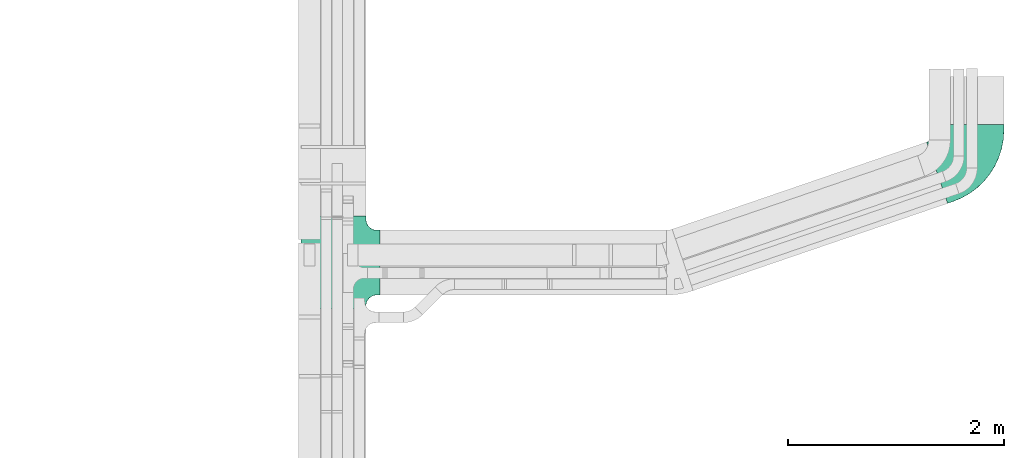
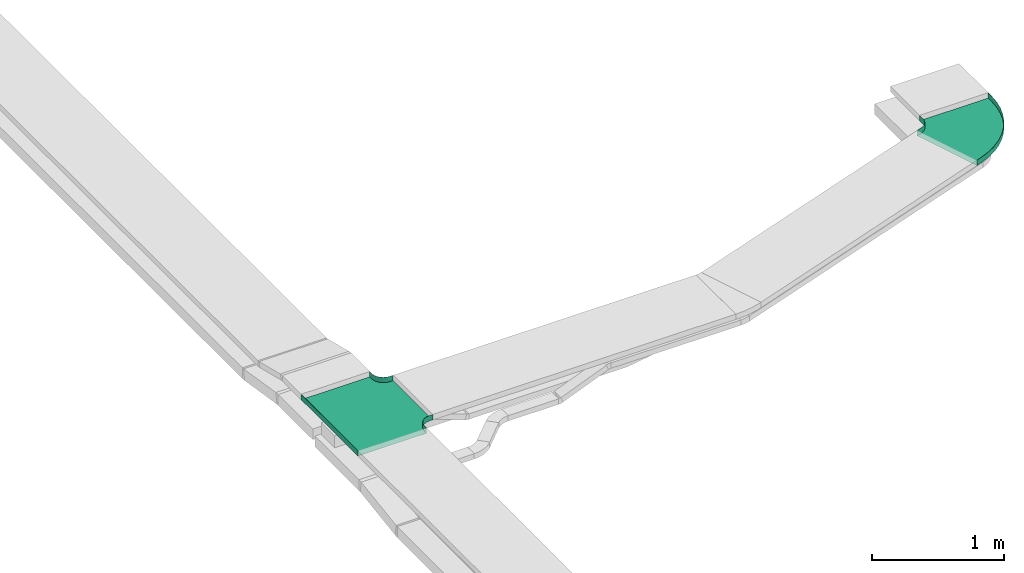
# One storey, part 25 of 28: 2 flow fittings.
"""IFC2X3 building model written with IfcOpenShell, lengths in millimetres."""

import ifcopenshell
import ifcopenshell.guid

model = None  # the IFC model being written
_history = None  # IfcOwnerHistory: only IFC2X3 demands one
_inside = {}  # id of a spatial element -> (the spatial element, [elements in it])
_under = {}  # id of a project, library or spatial element -> (it, [spatial elements below it])
_declared = {}  # id of a project -> (the project, [libraries it declares])
_typed = {}  # id of a type object -> (the type object, [elements of that type])
_made_of = {}  # id of a material, layer set ... -> (it, [elements and type objects made of it])


def new_model(schema):
    """Start an empty IFC model of exactly this schema.

    Asked for "IFC4X3", IfcOpenShell would pick the latest addendum, in which some entities
    have other attributes; the version numbers below select the first issue.
    IFC2X3 requires an IfcOwnerHistory on every rooted entity: one is made here for all.
    """
    global model, _history
    if schema == "IFC4X3":
        model = ifcopenshell.file(schema_version=(4, 3, 0, 0))
    else:
        model = ifcopenshell.file(schema=schema)
    _inside.clear()
    _under.clear()
    _declared.clear()
    _typed.clear()
    _made_of.clear()
    _history = None
    if model.schema == "IFC2X3":
        org = make("IfcOrganization", Name="unknown")
        user = make(
            "IfcPersonAndOrganization",
            ThePerson=make("IfcPerson", FamilyName="unknown"),
            TheOrganization=org,
        )
        app = make(
            "IfcApplication",
            ApplicationDeveloper=org,
            Version="unknown",
            ApplicationFullName="unknown",
            ApplicationIdentifier="unknown",
        )
        _history = make(
            "IfcOwnerHistory",
            OwningUser=user,
            OwningApplication=app,
            ChangeAction="ADDED",
            CreationDate=0,
        )
    return model


def make(cls, **values):
    """One entity of the class cls with the attributes given. An attribute that is None is left unset."""
    return model.create_entity(
        cls, **{name: value for name, value in values.items() if value is not None}
    )


def entity(cls, *values):
    """Any entity or typed value of the class cls, its attributes in the order of the schema. None: left unset."""
    e = model.create_entity(cls)
    for i, value in enumerate(values):
        if value is not None:
            e[i] = value
    return e


def rooted(cls, **values):
    """An entity with a GlobalId (a new one), such as an element, a storey or a relation."""
    return make(cls, GlobalId=ifcopenshell.guid.new(), OwnerHistory=_history, **values)


def si_unit(unit_type, name, prefix=None):
    """IfcSIUnit, for example si_unit("LENGTHUNIT", "METRE", prefix="MILLI")."""
    return make("IfcSIUnit", UnitType=unit_type, Prefix=prefix, Name=name)


def converted_unit(unit_type, name, factor, base, dimensions=None, offset=None):
    """IfcConversionBasedUnit, such as the inch: factor (a typed value) times the base unit."""
    return make(
        "IfcConversionBasedUnit"
        if offset is None
        else "IfcConversionBasedUnitWithOffset",
        ConversionOffset=offset,
        Dimensions=None
        if dimensions is None
        else entity("IfcDimensionalExponents", *dimensions),
        UnitType=unit_type,
        Name=name,
        ConversionFactor=make(
            "IfcMeasureWithUnit", ValueComponent=factor, UnitComponent=base
        ),
    )


def derived_unit(unit_type, elements):
    """IfcDerivedUnit: a product of units, each with its exponent."""
    return make(
        "IfcDerivedUnit",
        Elements=[
            make("IfcDerivedUnitElement", Unit=unit, Exponent=power)
            for unit, power in elements
        ],
        UnitType=unit_type,
    )


def assignment(units):
    """IfcUnitAssignment: the units of a project."""
    return None if units is None else make("IfcUnitAssignment", Units=units)


def point(xyz):
    """IfcCartesianPoint."""
    return None if xyz is None else make("IfcCartesianPoint", Coordinates=xyz)


def direction(xyz):
    """IfcDirection."""
    return None if xyz is None else make("IfcDirection", DirectionRatios=xyz)


def frame(location, z_axis=None, x_axis=None):
    """IfcAxis2Placement3D, a coordinate frame: its origin and axes. An axis left out is left unset."""
    return make(
        "IfcAxis2Placement3D",
        Location=point(location),
        Axis=direction(z_axis),
        RefDirection=direction(x_axis),
    )


def origin():
    """The frame at (0, 0, 0) with its axes left unset."""
    return frame((0.0, 0.0, 0.0))


def place(relative_to, where):
    """IfcLocalPlacement: puts the frame where relative to a parent placement (None: the world)."""
    return make(
        "IfcLocalPlacement", PlacementRelTo=relative_to, RelativePlacement=where
    )


def context(
    kind, dimensions, precision=None, world=None, true_north=None, identifier=None
):
    """IfcGeometricRepresentationContext, for example the 3D "Model" context."""
    return make(
        "IfcGeometricRepresentationContext",
        ContextIdentifier=identifier,
        ContextType=kind,
        CoordinateSpaceDimension=dimensions,
        Precision=precision,
        WorldCoordinateSystem=world,
        TrueNorth=true_north,
    )


def subcontext(parent, identifier, kind, view, scale=None):
    """IfcGeometricRepresentationSubContext, for example "Body" below "Model"."""
    return make(
        "IfcGeometricRepresentationSubContext",
        ContextIdentifier=identifier,
        ContextType=kind,
        ParentContext=parent,
        TargetScale=scale,
        TargetView=view,
    )


def project(units=None, contexts=None):
    """IfcProject with its units and contexts."""
    return rooted(
        "IfcProject",
        Name="project",
        RepresentationContexts=contexts,
        UnitsInContext=assignment(units),
    )


def spatial(cls, under=None, at=None, **own):
    """A site, building, storey or space (cls), placed at a placement, below another one or the project."""
    s = rooted(cls, ObjectPlacement=at, **own)
    if under is not None:
        _under.setdefault(under.id(), (under, []))[1].append(s)
    return s


def faces_of(points, faces, orient=None, outer=None):
    """IfcFace entities. A face is a list of loops; a loop is a list of indices into points, from 0.

    orient and outer hold one flag for each loop. By default every Orientation is true, the
    first loop of a face is its IfcFaceOuterBound and the others are IfcFaceBound.
    """
    made = []
    for i, loops in enumerate(faces):
        bounds = []
        for j, loop in enumerate(loops):
            is_outer = j == 0 if outer is None else outer[i][j]
            bounds.append(
                make(
                    "IfcFaceOuterBound" if is_outer else "IfcFaceBound",
                    Bound=make("IfcPolyLoop", Polygon=[points[k] for k in loop]),
                    Orientation=True if orient is None else orient[i][j],
                )
            )
        made.append(make("IfcFace", Bounds=bounds))
    return made


def faceted_brep(points, faces, orient=None, outer=None, voids=None):
    """IfcFacetedBrep: a solid bounded by flat faces; with voids (closed shells), ...WithVoids."""
    shared = [point(p) for p in points]
    hull = make("IfcClosedShell", CfsFaces=faces_of(shared, faces, orient, outer))
    if voids is None:
        return make("IfcFacetedBrep", Outer=hull)
    return make(
        "IfcFacetedBrepWithVoids",
        Outer=hull,
        Voids=[
            make(cls, CfsFaces=faces_of(shared, fs, o, b)) for cls, fs, o, b in voids
        ],
    )


def shape(context_of_items, identifier, shape_type, items):
    """IfcShapeRepresentation: the items that make up one representation, for example the "Body"."""
    return make(
        "IfcShapeRepresentation",
        ContextOfItems=context_of_items,
        RepresentationIdentifier=identifier,
        RepresentationType=shape_type,
        Items=items,
    )


def source(mapping_origin, context_of_items, identifier, shape_type, items):
    """IfcRepresentationMap: a shape defined once, which mapped items show again and again."""
    return make(
        "IfcRepresentationMap",
        MappingOrigin=mapping_origin,
        MappedRepresentation=shape(context_of_items, identifier, shape_type, items),
    )


def transform(
    local_origin,
    x_axis=None,
    y_axis=None,
    z_axis=None,
    scale=None,
    scale2=None,
    scale3=None,
    uniform=True,
):
    """IfcCartesianTransformationOperator3D, or its non-uniform kind. x_axis, y_axis, z_axis: its Axis1, 2, 3."""
    if uniform:
        return make(
            "IfcCartesianTransformationOperator3D",
            Axis1=direction(x_axis),
            Axis2=direction(y_axis),
            LocalOrigin=point(local_origin),
            Scale=scale,
            Axis3=direction(z_axis),
        )
    return make(
        "IfcCartesianTransformationOperator3DnonUniform",
        Axis1=direction(x_axis),
        Axis2=direction(y_axis),
        LocalOrigin=point(local_origin),
        Scale=scale,
        Axis3=direction(z_axis),
        Scale2=scale2,
        Scale3=scale3,
    )


def mapped(mapping_source, mapping_target):
    """IfcMappedItem: shows the shape of a source again, moved by a transform."""
    return make(
        "IfcMappedItem", MappingSource=mapping_source, MappingTarget=mapping_target
    )


def material(Name=None, Category=None):
    """IfcMaterial."""
    return make("IfcMaterial", Name=Name, Category=Category)


def made_of(thing, what):
    """Note that an element or type object is made of a material, layer set ...; save() writes the relation."""
    if what is not None:
        _made_of.setdefault(what.id(), (what, []))[1].append(thing)
    return thing


def type_object(cls, material=None, **own):
    """A type object (cls), such as IfcWallType, which elements share."""
    return made_of(rooted(cls, **own), material)


def type_shapes(of_type, sources):
    """Give a type object the sources (RepresentationMaps) that its elements show as mapped items."""
    of_type.RepresentationMaps = sources


def element(
    cls,
    number,
    at=None,
    inside=None,
    cuts=None,
    type_object=None,
    material=None,
    context=None,
    identifier="Body",
    shape_type=None,
    held_by="IfcProductDefinitionShape",
    body=None,
    shapes=None,
    **own,
):
    """One element of the class cls, such as IfcWall. Its Tag is "e" and its number.

    at: its placement. inside: the storey or other place that contains it. cuts: it is an
    opening in that element (IfcRelVoidsElement). A single representation is given by context,
    identifier, shape_type and body (its items); several are given by shapes. held_by: the class
    of the entity that holds the representations. save() writes the other relations.
    """
    e = rooted(cls, Tag="e%d" % number, ObjectPlacement=at, **own)
    if body is not None:
        shapes = [shape(context, identifier, shape_type, body)]
    if shapes is not None:
        e.Representation = make(held_by, Representations=shapes)
    if inside is not None:
        _inside.setdefault(inside.id(), (inside, []))[1].append(e)
    if cuts is not None:
        rooted(
            "IfcRelVoidsElement", RelatingBuildingElement=cuts, RelatedOpeningElement=e
        )
    if type_object is not None:
        _typed.setdefault(type_object.id(), (type_object, []))[1].append(e)
    return made_of(e, material)


def aggregate(whole, parts):
    """IfcRelAggregates: a whole, such as a stair, and the parts it consists of."""
    return rooted("IfcRelAggregates", RelatingObject=whole, RelatedObjects=parts)


def save(model, path):
    """Write the relations noted so far, then the file.

    IfcRelAggregates (storeys below a building ...), IfcRelContainedInSpatialStructure (elements
    in a storey), IfcRelDefinesByType, IfcRelAssociatesMaterial and IfcRelDeclares: one each for
    every whole, place, type object, material and project.
    """
    for whole, parts in _under.values():
        aggregate(whole, parts)
    for where, things in _inside.values():
        rooted(
            "IfcRelContainedInSpatialStructure",
            RelatedElements=things,
            RelatingStructure=where,
        )
    for kind, things in _typed.values():
        rooted("IfcRelDefinesByType", RelatedObjects=things, RelatingType=kind)
    for what, things in _made_of.values():
        rooted("IfcRelAssociatesMaterial", RelatedObjects=things, RelatingMaterial=what)
    for by, libraries in _declared.values():
        rooted("IfcRelDeclares", RelatingContext=by, RelatedDefinitions=libraries)
    model.write(path)


model = new_model("IFC2X3")

# Units and contexts
model_context = context("Model", 3, precision=0.01, world=origin(), true_north=direction((6.12303176911189e-17, 1.0)))
body_context = subcontext(model_context, "Body", "Model", "MODEL_VIEW")
ifc_project = project(units=[si_unit("LENGTHUNIT", "METRE", prefix="MILLI"), si_unit("AREAUNIT", "SQUARE_METRE"), si_unit("VOLUMEUNIT", "CUBIC_METRE"), converted_unit("PLANEANGLEUNIT", "DEGREE", entity("IfcRatioMeasure", 0.0174532925199433), si_unit("PLANEANGLEUNIT", "RADIAN"), dimensions=[0, 0, 0, 0, 0, 0, 0]), si_unit("MASSUNIT", "GRAM", prefix="KILO"), derived_unit("MASSDENSITYUNIT", [(si_unit("MASSUNIT", "GRAM", prefix="KILO"), 1), (si_unit("LENGTHUNIT", "METRE"), -3)]), derived_unit("MOMENTOFINERTIAUNIT", [(si_unit("LENGTHUNIT", "METRE"), 4)]), si_unit("TIMEUNIT", "SECOND"), si_unit("FREQUENCYUNIT", "HERTZ"), si_unit("THERMODYNAMICTEMPERATUREUNIT", "DEGREE_CELSIUS"), derived_unit("THERMALTRANSMITTANCEUNIT", [(si_unit("MASSUNIT", "GRAM", prefix="KILO"), 1), (si_unit("THERMODYNAMICTEMPERATUREUNIT", "KELVIN"), -1), (si_unit("TIMEUNIT", "SECOND"), -3)]), derived_unit("VOLUMETRICFLOWRATEUNIT", [(si_unit("LENGTHUNIT", "METRE"), 3), (si_unit("TIMEUNIT", "SECOND"), -1)]), derived_unit("MASSFLOWRATEUNIT", [(si_unit("MASSUNIT", "GRAM", prefix="KILO"), 1), (si_unit("TIMEUNIT", "SECOND"), -1)]), derived_unit("ROTATIONALFREQUENCYUNIT", [(si_unit("TIMEUNIT", "SECOND"), -1)]), si_unit("ELECTRICCURRENTUNIT", "AMPERE"), si_unit("ELECTRICVOLTAGEUNIT", "VOLT"), si_unit("POWERUNIT", "WATT"), si_unit("FORCEUNIT", "NEWTON", prefix="KILO"), si_unit("ILLUMINANCEUNIT", "LUX"), si_unit("LUMINOUSFLUXUNIT", "LUMEN"), si_unit("LUMINOUSINTENSITYUNIT", "CANDELA"), derived_unit("USERDEFINED", [(si_unit("MASSUNIT", "GRAM", prefix="KILO"), -1), (si_unit("LENGTHUNIT", "METRE"), -2), (si_unit("TIMEUNIT", "SECOND"), 3), (si_unit("LUMINOUSFLUXUNIT", "LUMEN"), 1)]), derived_unit("LINEARVELOCITYUNIT", [(si_unit("LENGTHUNIT", "METRE"), 1), (si_unit("TIMEUNIT", "SECOND"), -1)]), si_unit("PRESSUREUNIT", "PASCAL"), derived_unit("USERDEFINED", [(si_unit("LENGTHUNIT", "METRE"), -2), (si_unit("MASSUNIT", "GRAM", prefix="KILO"), 1), (si_unit("TIMEUNIT", "SECOND"), -2)]), derived_unit("LINEARFORCEUNIT", [(si_unit("MASSUNIT", "GRAM", prefix="KILO"), 1), (si_unit("LENGTHUNIT", "METRE"), 1), (si_unit("TIMEUNIT", "SECOND"), -2), (si_unit("LENGTHUNIT", "METRE"), -1)]), derived_unit("PLANARFORCEUNIT", [(si_unit("MASSUNIT", "GRAM", prefix="KILO"), 1), (si_unit("LENGTHUNIT", "METRE"), 1), (si_unit("TIMEUNIT", "SECOND"), -2), (si_unit("LENGTHUNIT", "METRE"), -2)])], contexts=[model_context])

# Site, building, storey
site_placement = place(None, origin())
site = spatial("IfcSite", under=ifc_project, at=site_placement, CompositionType="ELEMENT")
building_placement = place(site_placement, origin())
building = spatial("IfcBuilding", under=site, at=building_placement, CompositionType="ELEMENT")
storey_placement = place(building_placement, frame((0.0, 0.0, 4200.0)))
storey = spatial("IfcBuildingStorey", under=building, at=storey_placement, CompositionType="ELEMENT", Elevation=4200.0)

# Flow fittings
ifc_material = material()
cable_carrier_fitting_type_1 = type_object("IfcCableCarrierFittingType", PredefinedType="NOTDEFINED", material=ifc_material)
shared_shape_1 = source(origin(), body_context, "Body", "Brep", [
    faceted_brep([(-303.41, -374.12, 25.0), (-300.0, -400.0, 25.0), (-300.0, -430.0, 25.0), (-299.2, -430.0, 25.0), (-299.2, -400.0, 25.0), (-302.63, -373.91, 25.0), (-312.7, -349.6, 25.0), (-328.72, -328.72, 25.0), (-349.6, -312.7, 25.0), (-373.91, -302.63, 25.0), (-400.0, -299.2, 25.0), (-430.0, -299.2, 25.0), (-430.0, -300.0, 25.0), (-400.0, -300.0, 25.0), (-374.12, -303.41, 25.0), (-350.0, -313.4, 25.0), (-329.29, -329.29, 25.0), (-313.4, -350.0, 25.0), (430.0, -300.0, 25.0), (430.0, -299.2, 25.0), (400.0, -299.2, 25.0), (373.91, -302.63, 25.0), (349.6, -312.7, 25.0), (328.72, -328.72, 25.0), (312.7, -349.6, 25.0), (302.63, -373.91, 25.0), (299.2, -400.0, 25.0), (299.2, -430.0, 25.0), (300.0, -430.0, 25.0), (300.0, -400.0, 25.0), (303.41, -374.12, 25.0), (313.4, -350.0, 25.0), (329.29, -329.29, 25.0), (350.0, -313.4, 25.0), (374.12, -303.41, 25.0), (400.0, -300.0, 25.0), (430.0, 299.2, 25.0), (430.0, 300.0, 25.0), (-430.0, 300.0, 25.0), (-430.0, 299.2, 25.0), (-430.0, -300.0, -25.0), (-430.0, 300.0, -25.0), (430.0, 300.0, -25.0), (430.0, -300.0, -25.0), (400.0, -300.0, -25.0), (374.12, -303.41, -25.0), (350.0, -313.4, -25.0), (329.29, -329.29, -25.0), (313.4, -350.0, -25.0), (303.41, -374.12, -25.0), (300.0, -400.0, -25.0), (300.0, -430.0, -25.0), (-300.0, -430.0, -25.0), (-300.0, -400.0, -25.0), (-303.41, -374.12, -25.0), (-313.4, -350.0, -25.0), (-329.29, -329.29, -25.0), (-350.0, -313.4, -25.0), (-374.12, -303.41, -25.0), (-400.0, -300.0, -25.0), (-300.0, -400.0, -24.2), (299.2, -430.0, -24.2), (-299.2, -430.0, -24.2), (-299.2, -400.0, -24.2), (-400.0, -299.2, -24.2), (-430.0, -299.2, -24.2), (430.0, -299.2, -24.2), (400.0, -299.2, -24.2), (-430.0, 299.2, -24.2), (-400.0, -300.0, -24.2), (400.0, -300.0, -24.2), (430.0, 299.2, -24.2), (299.2, -400.0, -24.2), (300.0, -400.0, -24.2), (-373.91, -302.63, -24.2), (-349.6, -312.7, -24.2), (-328.72, -328.72, -24.2), (-312.7, -349.6, -24.2), (-302.63, -373.91, -24.2), (302.63, -373.91, -24.2), (312.7, -349.6, -24.2), (328.72, -328.72, -24.2), (349.6, -312.7, -24.2), (373.91, -302.63, -24.2)], [[[0, 1, 2, 3, 4, 5, 6, 7, 8, 9, 10, 11, 12, 13, 14, 15, 16, 17]], [[18, 19, 20, 21, 22, 23, 24, 25, 26, 27, 28, 29, 30, 31, 32, 33, 34, 35]], [[36, 37, 38, 39]], [[40, 41, 42, 43, 44, 45, 46, 47, 48, 49, 50, 51, 52, 53, 54, 55, 56, 57, 58, 59]], [[2, 1, 60, 53, 52]], [[3, 2, 52, 51, 28, 27, 61, 62]], [[4, 3, 62, 63]], [[11, 10, 64, 65]], [[20, 19, 66, 67]], [[39, 38, 41, 40, 12, 11, 65, 68]], [[13, 12, 40, 59, 69]], [[18, 35, 70, 44, 43]], [[19, 18, 43, 42, 37, 36, 71, 66]], [[27, 26, 72, 61]], [[29, 28, 51, 50, 73]], [[38, 37, 42, 41]], [[36, 39, 68, 71]], [[68, 65, 64, 74, 75, 76, 77, 78, 63, 62, 61, 72, 79, 80, 81, 82, 83, 67, 66, 71]], [[14, 13, 69, 59, 58]], [[58, 57, 15, 14]], [[15, 57, 56, 16]], [[0, 17, 55, 54]], [[0, 54, 53, 60, 1]], [[55, 17, 16, 56]], [[5, 4, 63, 78]], [[6, 5, 78, 77]], [[7, 6, 77, 76]], [[8, 7, 76, 75]], [[9, 8, 75, 74]], [[10, 9, 74, 64]], [[21, 20, 67, 83]], [[22, 21, 83, 82]], [[23, 22, 82, 81]], [[81, 80, 24, 23]], [[24, 80, 79, 25]], [[79, 72, 26, 25]], [[30, 29, 73, 50, 49]], [[31, 30, 49, 48]], [[31, 48, 47, 32]], [[33, 32, 47, 46]], [[45, 34, 33, 46]], [[34, 45, 44, 70, 35]]]),
])
type_shapes(cable_carrier_fitting_type_1, [shared_shape_1])
flow_fitting_1_placement = place(storey_placement, frame((61794.03, 8693.32, 2884.5), z_axis=(0.0, 0.0, 1.0), x_axis=(0.0, 1.0, 0.0)))
element("IfcFlowFitting", 1, at=flow_fitting_1_placement, inside=storey, type_object=cable_carrier_fitting_type_1, material=ifc_material, Name="470_DKC_S5_T", context=body_context, shape_type="MappedRepresentation", body=[
    mapped(shared_shape_1, transform((0.0, 0.0, 0.0), scale=1.0)),
])
cable_carrier_fitting_type_2 = type_object("IfcCableCarrierFittingType", Name="470_DKC_S5_CPO 45 horizontal angle:-", PredefinedType="NOTDEFINED", material=ifc_material)
shared_shape_2 = source(origin(), body_context, "Body", "Brep", [
    faceted_brep([(-336.97, -300.0, -25.0), (-336.97, -300.0, 25.0), (-336.97, -299.2, 25.0), (-336.97, -299.2, -24.2), (-336.97, 299.2, -24.2), (-336.97, 299.2, 25.0), (-336.97, 300.0, 25.0), (-336.97, 300.0, -25.0), (-285.78, -300.0, -25.0), (-285.78, -300.0, 25.0), (-199.15, -294.62, 25.0), (-113.85, -278.56, 25.0), (-31.2, -252.07, 25.0), (47.54, -215.55, 25.0), (121.15, -169.57, 25.0), (188.51, -114.84, 25.0), (248.57, -52.19, 25.0), (300.42, 17.42, 25.0), (343.26, 92.9, 25.0), (376.43, 173.11, 25.0), (393.03, 221.54, 25.0), (392.27, 221.8, 25.0), (375.68, 173.37, 25.0), (342.54, 93.25, 25.0), (299.75, 17.85, 25.0), (247.96, -51.67, 25.0), (187.96, -114.25, 25.0), (120.68, -168.92, 25.0), (47.15, -214.85, 25.0), (-31.49, -251.32, 25.0), (-114.05, -277.78, 25.0), (-199.25, -293.83, 25.0), (-285.78, -299.2, 25.0), (-285.78, 299.2, 25.0), (-255.01, 304.01, 25.0), (-227.18, 317.98, 25.0), (-204.94, 339.78, 25.0), (-190.42, 367.33, 25.0), (-173.82, 415.76, 25.0), (-174.58, 416.02, 25.0), (-191.17, 367.59, 25.0), (-205.58, 340.26, 25.0), (-227.64, 318.63, 25.0), (-255.25, 304.77, 25.0), (-285.78, 300.0, 25.0), (-285.78, -299.2, -24.2), (-199.25, -293.83, -24.2), (-114.05, -277.78, -24.2), (-31.49, -251.32, -24.2), (47.15, -214.85, -24.2), (120.68, -168.92, -24.2), (187.96, -114.25, -24.2), (247.96, -51.67, -24.2), (299.75, 17.85, -24.2), (342.54, 93.25, -24.2), (375.68, 173.37, -24.2), (392.27, 221.8, -24.2), (-173.82, 415.76, -24.2), (-190.42, 367.33, -24.2), (-204.94, 339.78, -24.2), (-227.18, 317.98, -24.2), (-255.01, 304.01, -24.2), (-285.78, 299.2, -24.2), (-285.78, 300.0, -25.0), (-199.15, -294.62, -25.0), (-255.25, 304.77, -25.0), (-227.64, 318.63, -25.0), (-205.58, 340.26, -25.0), (-191.17, 367.59, -25.0), (-174.58, 416.02, -25.0), (393.03, 221.54, -25.0), (376.43, 173.11, -25.0), (343.26, 92.9, -25.0), (300.42, 17.42, -25.0), (248.57, -52.19, -25.0), (188.51, -114.84, -25.0), (121.15, -169.57, -25.0), (47.54, -215.55, -25.0), (-31.2, -252.07, -25.0), (-113.85, -278.56, -25.0)], [[[0, 1, 2, 3, 4, 5, 6, 7]], [[1, 0, 8, 9]], [[1, 9, 10, 11, 12, 13, 14, 15, 16, 17, 18, 19, 20, 21, 22, 23, 24, 25, 26, 27, 28, 29, 30, 31, 32, 2]], [[5, 33, 34, 35, 36, 37, 38, 39, 40, 41, 42, 43, 44, 6]], [[3, 2, 32, 45]], [[4, 3, 45, 46, 47, 48, 49, 50, 51, 52, 53, 54, 55, 56, 57, 58, 59, 60, 61, 62]], [[5, 4, 62, 33]], [[7, 6, 44, 63]], [[64, 8, 0, 7, 63, 65, 66, 67, 68, 69, 70, 71, 72, 73, 74, 75, 76, 77, 78, 79]], [[10, 9, 8, 64]], [[77, 76, 14, 13]], [[11, 10, 64, 79]], [[12, 78, 77, 13]], [[78, 12, 11, 79]], [[15, 75, 74, 16]], [[17, 73, 72, 18]], [[74, 73, 17, 16]], [[18, 72, 71, 19]], [[75, 15, 14, 76]], [[46, 45, 32, 31]], [[28, 27, 50, 49]], [[47, 46, 31, 30]], [[28, 49, 48, 29]], [[30, 29, 48, 47]], [[52, 51, 26, 25]], [[54, 53, 24, 23]], [[25, 24, 53, 52]], [[55, 54, 23, 22]], [[27, 26, 51, 50]], [[62, 61, 34, 33]], [[34, 61, 60, 35]], [[59, 58, 37, 36]], [[59, 36, 35, 60]], [[43, 65, 63, 44]], [[42, 66, 65, 43]], [[41, 40, 68, 67]], [[66, 42, 41, 67]], [[69, 39, 38, 57, 56, 21, 20, 70]], [[19, 71, 70, 20]], [[55, 22, 21, 56]], [[37, 58, 57, 38]], [[68, 40, 39, 69]]]),
])
type_shapes(cable_carrier_fitting_type_2, [shared_shape_2])
flow_fitting_2_placement = place(storey_placement, frame((67694.03, 9633.32, 2884.5), z_axis=(8.12959457272506e-06, 0.0, 1.0), x_axis=(0.946011941324184, 0.324131773840365, -7.69069354417633e-06)))
element("IfcFlowFitting", 2, at=flow_fitting_2_placement, inside=storey, type_object=cable_carrier_fitting_type_2, material=ifc_material, Name="470_DKC_S5_45 horizontal angle", ObjectType="470_DKC_S5_CPO 45 horizontal angle:-", context=body_context, shape_type="MappedRepresentation", body=[
    mapped(shared_shape_2, transform((0.0, 0.0, 0.0), scale=1.0)),
])

save(model, "model.ifc")
